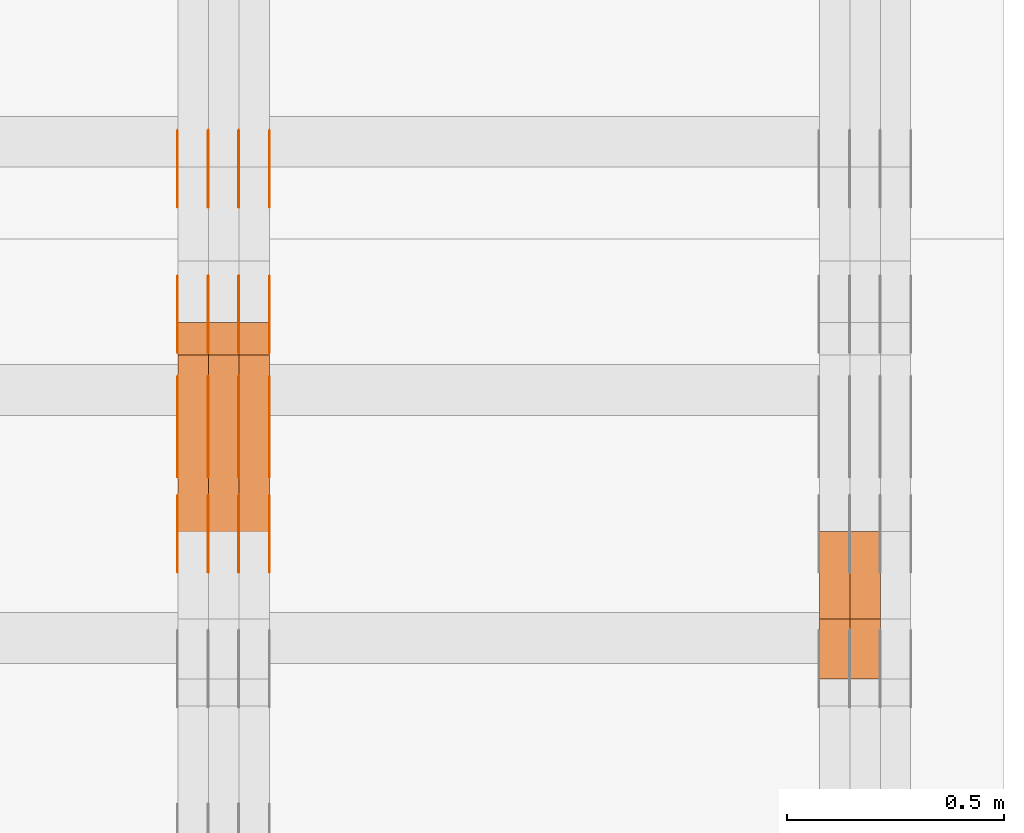
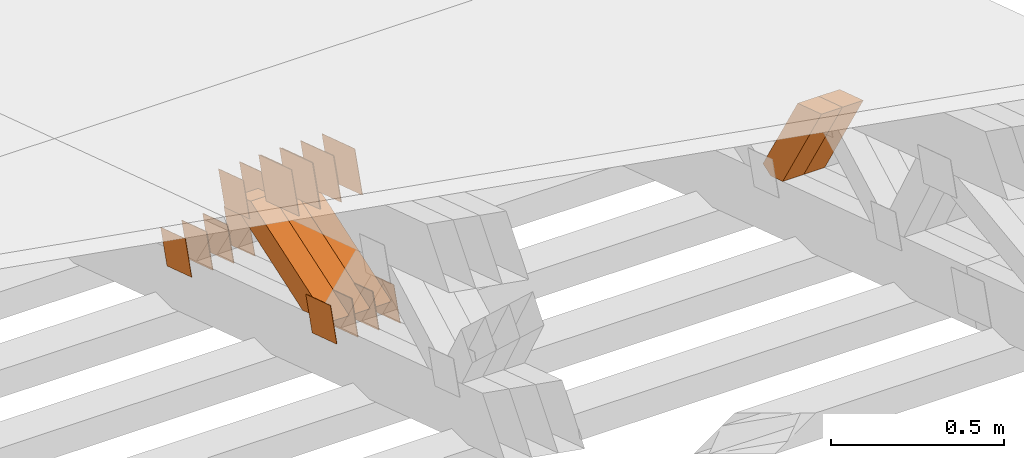
# One storey, part 366 of 385: 29 proxies.
"""IFC2X3 building model written with IfcOpenShell, lengths in millimetres."""

from ifc_helpers import new_model, entity, si_unit, converted_unit, derived_unit, direction, frame, origin, place, context, subcontext, project, spatial, polyline, outline, extrude, source, transform, mapped, material, type_object, type_shapes, element, save


model = new_model("IFC2X3")

# Units and contexts
model_context = context("Model", 3, precision=0.01, world=origin(), true_north=direction((6.12303176911189e-17, 1.0)))
body_context = subcontext(model_context, "Body", "Model", "MODEL_VIEW")
ifc_project = project(units=[si_unit("LENGTHUNIT", "METRE", prefix="MILLI"), si_unit("AREAUNIT", "SQUARE_METRE"), si_unit("VOLUMEUNIT", "CUBIC_METRE"), converted_unit("PLANEANGLEUNIT", "DEGREE", entity("IfcRatioMeasure", 0.0174532925199433), si_unit("PLANEANGLEUNIT", "RADIAN"), dimensions=[0, 0, 0, 0, 0, 0, 0]), si_unit("MASSUNIT", "GRAM", prefix="KILO"), derived_unit("MASSDENSITYUNIT", [(si_unit("MASSUNIT", "GRAM", prefix="KILO"), 1), (si_unit("LENGTHUNIT", "METRE"), -3)]), si_unit("TIMEUNIT", "SECOND"), si_unit("FREQUENCYUNIT", "HERTZ"), si_unit("THERMODYNAMICTEMPERATUREUNIT", "DEGREE_CELSIUS"), derived_unit("THERMALTRANSMITTANCEUNIT", [(si_unit("MASSUNIT", "GRAM", prefix="KILO"), 1), (si_unit("THERMODYNAMICTEMPERATUREUNIT", "KELVIN"), -1), (si_unit("TIMEUNIT", "SECOND"), -3)]), derived_unit("VOLUMETRICFLOWRATEUNIT", [(si_unit("LENGTHUNIT", "METRE"), 3), (si_unit("TIMEUNIT", "SECOND"), -1)]), si_unit("ELECTRICCURRENTUNIT", "AMPERE"), si_unit("ELECTRICVOLTAGEUNIT", "VOLT"), si_unit("POWERUNIT", "WATT"), si_unit("FORCEUNIT", "NEWTON", prefix="KILO"), si_unit("ILLUMINANCEUNIT", "LUX"), si_unit("LUMINOUSFLUXUNIT", "LUMEN"), si_unit("LUMINOUSINTENSITYUNIT", "CANDELA"), derived_unit("USERDEFINED", [(si_unit("MASSUNIT", "GRAM", prefix="KILO"), -1), (si_unit("LENGTHUNIT", "METRE"), -2), (si_unit("TIMEUNIT", "SECOND"), 3), (si_unit("LUMINOUSFLUXUNIT", "LUMEN"), 1)]), derived_unit("LINEARVELOCITYUNIT", [(si_unit("LENGTHUNIT", "METRE"), 1), (si_unit("TIMEUNIT", "SECOND"), -1)]), si_unit("PRESSUREUNIT", "PASCAL"), derived_unit("USERDEFINED", [(si_unit("LENGTHUNIT", "METRE"), -2), (si_unit("MASSUNIT", "GRAM", prefix="KILO"), 1), (si_unit("TIMEUNIT", "SECOND"), -2)])], contexts=[model_context])

# Site, building, storey
site_placement = place(None, origin())
site = spatial("IfcSite", under=ifc_project, at=site_placement, CompositionType="ELEMENT")
building_placement = place(site_placement, origin())
building = spatial("IfcBuilding", under=site, at=building_placement, CompositionType="ELEMENT")
storey_placement = place(building_placement, origin())
storey = spatial("IfcBuildingStorey", under=building, at=storey_placement, Name="Default", CompositionType="ELEMENT", Elevation=0.0)

# Proxies
ifc_material_1 = material(Name="IfcSurfaceStyle #599920")
building_element_proxy_type_1 = type_object("IfcBuildingElementProxyType", Name="T2-W34 599918", PredefinedType="NOTDEFINED", material=ifc_material_1)
shared_shape_1 = source(origin(), body_context, "Body", "SweptSolid", [
    extrude(outline(polyline([(-197.657161937088, -47.499796538607), (193.17680883218, -47.499796538607), (182.92464491562, -1.98968224184526e-05), (128.354123102956, 47.4998064870182), (-306.798414913668, 47.4998064870182), (-197.657161937088, -47.499796538607)])), frame((193.176852028916, 47.4998566383869, 0.0), z_axis=(0.0, 0.0, 1.0), x_axis=(-1.0, 0.0, 0.0)), (0.0, 0.0, 1.0), 70.0),
])
type_shapes(building_element_proxy_type_1, [shared_shape_1])
proxy_1_placement = place(building_placement, frame((49790.0, 19987.8030409043, 2165.75390635484), z_axis=(-1.0, 0.0, 0.0), x_axis=(0.0, -0.514479403471631, 0.857502736674044)))
element("IfcBuildingElementProxy", 1, at=proxy_1_placement, inside=storey, type_object=building_element_proxy_type_1, material=ifc_material_1, Name="T2-W34", context=body_context, shape_type="MappedRepresentation", body=[
    mapped(shared_shape_1, transform((0.0, 0.0, 0.0), scale=1.0)),
])
ifc_material_2 = material(Name="IfcSurfaceStyle #599854")
building_element_proxy_type_2 = type_object("IfcBuildingElementProxyType", Name="T2-W34 599852", PredefinedType="NOTDEFINED", material=ifc_material_2)
shared_shape_2 = source(origin(), body_context, "Body", "SweptSolid", [
    extrude(outline(polyline([(-197.657161937088, -47.499796538607), (193.17680883218, -47.499796538607), (182.92464491562, -1.98968224184526e-05), (128.354123102956, 47.4998064870182), (-306.798414913668, 47.4998064870182), (-197.657161937088, -47.499796538607)])), frame((193.176852028916, 47.4998566383869, 0.0), z_axis=(0.0, 0.0, 1.0), x_axis=(-1.0, 0.0, 0.0)), (0.0, 0.0, 1.0), 70.0),
])
type_shapes(building_element_proxy_type_2, [shared_shape_2])
proxy_2_placement = place(building_placement, frame((49720.0, 19987.8030409043, 2165.75390635484), z_axis=(-1.0, 0.0, 0.0), x_axis=(0.0, -0.514479403471631, 0.857502736674044)))
element("IfcBuildingElementProxy", 2, at=proxy_2_placement, inside=storey, type_object=building_element_proxy_type_2, material=ifc_material_2, Name="T2-W34", context=body_context, shape_type="MappedRepresentation", body=[
    mapped(shared_shape_2, transform((0.0, 0.0, 0.0), scale=1.0)),
])
ifc_material_3 = material(Name="IfcSurfaceStyle #590970")
building_element_proxy_type_3 = type_object("IfcBuildingElementProxyType", PredefinedType="NOTDEFINED", material=ifc_material_3)
shared_shape_3 = source(origin(), body_context, "Body", "SweptSolid", [
    extrude(outline(polyline([(-74.9998605591059, -59.9999264677526), (74.999875428623, -59.9999264677526), (74.9998605591068, 59.9999264677526), (-74.9998754286239, 59.9999264677526), (-74.9998605591059, -59.9999264677526)])), frame((75.0000889884782, 60.0000460315623, 0.0), z_axis=(0.0, 0.0, 1.0), x_axis=(-1.0, 0.0, 0.0)), (0.0, 0.0, 1.0), 1.3),
])
type_shapes(building_element_proxy_type_3, [shared_shape_3])
proxy_3_placement = place(building_placement, frame((48386.3, 20621.9679769682, 2241.76551219004), z_axis=(-1.0, 0.0, 0.0), x_axis=(0.0, -0.951056516295154, 0.309016994374948)))
element("IfcBuildingElementProxy", 3, at=proxy_3_placement, inside=storey, type_object=building_element_proxy_type_3, material=ifc_material_3, context=body_context, shape_type="MappedRepresentation", body=[
    mapped(shared_shape_3, transform((0.0, 0.0, 0.0), scale=1.0)),
])
ifc_material_4 = material(Name="IfcSurfaceStyle #590913")
building_element_proxy_type_4 = type_object("IfcBuildingElementProxyType", PredefinedType="NOTDEFINED", material=ifc_material_4)
shared_shape_4 = source(origin(), body_context, "Body", "SweptSolid", [
    extrude(outline(polyline([(-74.9998605591059, -59.9999264677526), (74.999875428623, -59.9999264677526), (74.9998605591068, 59.9999264677526), (-74.9998754286239, 59.9999264677526), (-74.9998605591059, -59.9999264677526)])), frame((75.0000889884782, 60.0000460315623, 0.0), z_axis=(0.0, 0.0, 1.0), x_axis=(-1.0, 0.0, 0.0)), (0.0, 0.0, 1.0), 1.3),
])
type_shapes(building_element_proxy_type_4, [shared_shape_4])
proxy_4_placement = place(building_placement, frame((48315.0, 20621.9679769682, 2241.76551219004), z_axis=(-1.0, 0.0, 0.0), x_axis=(0.0, -0.951056516295154, 0.309016994374948)))
element("IfcBuildingElementProxy", 4, at=proxy_4_placement, inside=storey, type_object=building_element_proxy_type_4, material=ifc_material_4, context=body_context, shape_type="MappedRepresentation", body=[
    mapped(shared_shape_4, transform((0.0, 0.0, 0.0), scale=1.0)),
])
ifc_material_5 = material(Name="IfcSurfaceStyle #590856")
building_element_proxy_type_5 = type_object("IfcBuildingElementProxyType", PredefinedType="NOTDEFINED", material=ifc_material_5)
shared_shape_5 = source(origin(), body_context, "Body", "SweptSolid", [
    extrude(outline(polyline([(-74.9998605591059, -59.9999264677526), (74.999875428623, -59.9999264677526), (74.9998605591068, 59.9999264677526), (-74.9998754286239, 59.9999264677526), (-74.9998605591059, -59.9999264677526)])), frame((75.0000889884782, 60.0000460315623, 0.0), z_axis=(0.0, 0.0, 1.0), x_axis=(-1.0, 0.0, 0.0)), (0.0, 0.0, 1.0), 1.3),
])
type_shapes(building_element_proxy_type_5, [shared_shape_5])
proxy_5_placement = place(building_placement, frame((48316.3, 20621.9679769682, 2241.76551219004), z_axis=(-1.0, 0.0, 0.0), x_axis=(0.0, -0.951056516295154, 0.309016994374948)))
element("IfcBuildingElementProxy", 5, at=proxy_5_placement, inside=storey, type_object=building_element_proxy_type_5, material=ifc_material_5, context=body_context, shape_type="MappedRepresentation", body=[
    mapped(shared_shape_5, transform((0.0, 0.0, 0.0), scale=1.0)),
])
ifc_material_6 = material(Name="IfcSurfaceStyle #590799")
building_element_proxy_type_6 = type_object("IfcBuildingElementProxyType", PredefinedType="NOTDEFINED", material=ifc_material_6)
shared_shape_6 = source(origin(), body_context, "Body", "SweptSolid", [
    extrude(outline(polyline([(-74.9998605591059, -59.9999264677526), (74.999875428623, -59.9999264677526), (74.9998605591068, 59.9999264677526), (-74.9998754286239, 59.9999264677526), (-74.9998605591059, -59.9999264677526)])), frame((75.0000889884782, 60.0000460315623, 0.0), z_axis=(0.0, 0.0, 1.0), x_axis=(-1.0, 0.0, 0.0)), (0.0, 0.0, 1.0), 1.29999999999999),
])
type_shapes(building_element_proxy_type_6, [shared_shape_6])
proxy_6_placement = place(building_placement, frame((48245.0, 20621.9679769682, 2241.76551219004), z_axis=(-1.0, 0.0, 0.0), x_axis=(0.0, -0.951056516295154, 0.309016994374948)))
element("IfcBuildingElementProxy", 6, at=proxy_6_placement, inside=storey, type_object=building_element_proxy_type_6, material=ifc_material_6, context=body_context, shape_type="MappedRepresentation", body=[
    mapped(shared_shape_6, transform((0.0, 0.0, 0.0), scale=1.0)),
])
ifc_material_7 = material(Name="IfcSurfaceStyle #590742")
building_element_proxy_type_7 = type_object("IfcBuildingElementProxyType", PredefinedType="NOTDEFINED", material=ifc_material_7)
shared_shape_7 = source(origin(), body_context, "Body", "SweptSolid", [
    extrude(outline(polyline([(-74.9998605591059, -59.9999264677526), (74.999875428623, -59.9999264677526), (74.9998605591068, 59.9999264677526), (-74.9998754286239, 59.9999264677526), (-74.9998605591059, -59.9999264677526)])), frame((75.0000889884782, 60.0000460315623, 0.0), z_axis=(0.0, 0.0, 1.0), x_axis=(-1.0, 0.0, 0.0)), (0.0, 0.0, 1.0), 1.29999999999999),
])
type_shapes(building_element_proxy_type_7, [shared_shape_7])
proxy_7_placement = place(building_placement, frame((48246.3, 20621.9679769682, 2241.76551219004), z_axis=(-1.0, 0.0, 0.0), x_axis=(0.0, -0.951056516295154, 0.309016994374948)))
element("IfcBuildingElementProxy", 7, at=proxy_7_placement, inside=storey, type_object=building_element_proxy_type_7, material=ifc_material_7, context=body_context, shape_type="MappedRepresentation", body=[
    mapped(shared_shape_7, transform((0.0, 0.0, 0.0), scale=1.0)),
])
ifc_material_8 = material(Name="IfcSurfaceStyle #590685")
building_element_proxy_type_8 = type_object("IfcBuildingElementProxyType", PredefinedType="NOTDEFINED", material=ifc_material_8)
shared_shape_8 = source(origin(), body_context, "Body", "SweptSolid", [
    extrude(outline(polyline([(-74.9998605591059, -59.9999264677526), (74.999875428623, -59.9999264677526), (74.9998605591068, 59.9999264677526), (-74.9998754286239, 59.9999264677526), (-74.9998605591059, -59.9999264677526)])), frame((75.0000889884782, 60.0000460315623, 0.0), z_axis=(0.0, 0.0, 1.0), x_axis=(-1.0, 0.0, 0.0)), (0.0, 0.0, 1.0), 1.29999999999999),
])
type_shapes(building_element_proxy_type_8, [shared_shape_8])
proxy_8_placement = place(building_placement, frame((48175.0, 20621.9679769682, 2241.76551219004), z_axis=(-1.0, 0.0, 0.0), x_axis=(0.0, -0.951056516295154, 0.309016994374948)))
element("IfcBuildingElementProxy", 8, at=proxy_8_placement, inside=storey, type_object=building_element_proxy_type_8, material=ifc_material_8, context=body_context, shape_type="MappedRepresentation", body=[
    mapped(shared_shape_8, transform((0.0, 0.0, 0.0), scale=1.0)),
])
ifc_material_9 = material(Name="IfcSurfaceStyle #589260")
building_element_proxy_type_9 = type_object("IfcBuildingElementProxyType", PredefinedType="NOTDEFINED", material=ifc_material_9)
shared_shape_9 = source(origin(), body_context, "Body", "SweptSolid", [
    extrude(outline(polyline([(-100.000260677523, -72.0000050220369), (100.000341220114, -72.0000050220369), (99.9997962944585, 72.0000050220369), (-99.9998768370492, 72.0000050220369), (-100.000260677523, -72.0000050220369)])), frame((100.000341220114, 72.0001826453454, 0.0), z_axis=(0.0, 0.0, 1.0), x_axis=(-1.0, 0.0, 0.0)), (0.0, 0.0, 1.0), 1.3),
])
type_shapes(building_element_proxy_type_9, [shared_shape_9])
proxy_9_placement = place(building_placement, frame((48386.3, 20382.8706354426, 2409.35285895246), z_axis=(-1.0, 0.0, 0.0), x_axis=(0.0, -0.951056516295154, 0.309016994374948)))
element("IfcBuildingElementProxy", 9, at=proxy_9_placement, inside=storey, type_object=building_element_proxy_type_9, material=ifc_material_9, context=body_context, shape_type="MappedRepresentation", body=[
    mapped(shared_shape_9, transform((0.0, 0.0, 0.0), scale=1.0)),
])
ifc_material_10 = material(Name="IfcSurfaceStyle #589203")
building_element_proxy_type_10 = type_object("IfcBuildingElementProxyType", PredefinedType="NOTDEFINED", material=ifc_material_10)
shared_shape_10 = source(origin(), body_context, "Body", "SweptSolid", [
    extrude(outline(polyline([(-100.000260677523, -72.0000050220369), (100.000341220114, -72.0000050220369), (99.9997962944585, 72.0000050220369), (-99.9998768370492, 72.0000050220369), (-100.000260677523, -72.0000050220369)])), frame((100.000341220114, 72.0001826453454, 0.0), z_axis=(0.0, 0.0, 1.0), x_axis=(-1.0, 0.0, 0.0)), (0.0, 0.0, 1.0), 1.3),
])
type_shapes(building_element_proxy_type_10, [shared_shape_10])
proxy_10_placement = place(building_placement, frame((48315.0, 20382.8706354426, 2409.35285895246), z_axis=(-1.0, 0.0, 0.0), x_axis=(0.0, -0.951056516295154, 0.309016994374948)))
element("IfcBuildingElementProxy", 10, at=proxy_10_placement, inside=storey, type_object=building_element_proxy_type_10, material=ifc_material_10, context=body_context, shape_type="MappedRepresentation", body=[
    mapped(shared_shape_10, transform((0.0, 0.0, 0.0), scale=1.0)),
])
ifc_material_11 = material(Name="IfcSurfaceStyle #589146")
building_element_proxy_type_11 = type_object("IfcBuildingElementProxyType", PredefinedType="NOTDEFINED", material=ifc_material_11)
shared_shape_11 = source(origin(), body_context, "Body", "SweptSolid", [
    extrude(outline(polyline([(-100.000260677523, -72.0000050220369), (100.000341220114, -72.0000050220369), (99.9997962944585, 72.0000050220369), (-99.9998768370492, 72.0000050220369), (-100.000260677523, -72.0000050220369)])), frame((100.000341220114, 72.0001826453454, 0.0), z_axis=(0.0, 0.0, 1.0), x_axis=(-1.0, 0.0, 0.0)), (0.0, 0.0, 1.0), 1.3),
])
type_shapes(building_element_proxy_type_11, [shared_shape_11])
proxy_11_placement = place(building_placement, frame((48316.3, 20382.8706354426, 2409.35285895246), z_axis=(-1.0, 0.0, 0.0), x_axis=(0.0, -0.951056516295154, 0.309016994374948)))
element("IfcBuildingElementProxy", 11, at=proxy_11_placement, inside=storey, type_object=building_element_proxy_type_11, material=ifc_material_11, context=body_context, shape_type="MappedRepresentation", body=[
    mapped(shared_shape_11, transform((0.0, 0.0, 0.0), scale=1.0)),
])
ifc_material_12 = material(Name="IfcSurfaceStyle #589089")
building_element_proxy_type_12 = type_object("IfcBuildingElementProxyType", PredefinedType="NOTDEFINED", material=ifc_material_12)
shared_shape_12 = source(origin(), body_context, "Body", "SweptSolid", [
    extrude(outline(polyline([(-100.000260677523, -72.0000050220369), (100.000341220114, -72.0000050220369), (99.9997962944585, 72.0000050220369), (-99.9998768370492, 72.0000050220369), (-100.000260677523, -72.0000050220369)])), frame((100.000341220114, 72.0001826453454, 0.0), z_axis=(0.0, 0.0, 1.0), x_axis=(-1.0, 0.0, 0.0)), (0.0, 0.0, 1.0), 1.29999999999998),
])
type_shapes(building_element_proxy_type_12, [shared_shape_12])
proxy_12_placement = place(building_placement, frame((48245.0, 20382.8706354426, 2409.35285895246), z_axis=(-1.0, 0.0, 0.0), x_axis=(0.0, -0.951056516295154, 0.309016994374948)))
element("IfcBuildingElementProxy", 12, at=proxy_12_placement, inside=storey, type_object=building_element_proxy_type_12, material=ifc_material_12, context=body_context, shape_type="MappedRepresentation", body=[
    mapped(shared_shape_12, transform((0.0, 0.0, 0.0), scale=1.0)),
])
ifc_material_13 = material(Name="IfcSurfaceStyle #589032")
building_element_proxy_type_13 = type_object("IfcBuildingElementProxyType", PredefinedType="NOTDEFINED", material=ifc_material_13)
shared_shape_13 = source(origin(), body_context, "Body", "SweptSolid", [
    extrude(outline(polyline([(-100.000260677523, -72.0000050220369), (100.000341220114, -72.0000050220369), (99.9997962944585, 72.0000050220369), (-99.9998768370492, 72.0000050220369), (-100.000260677523, -72.0000050220369)])), frame((100.000341220114, 72.0001826453454, 0.0), z_axis=(0.0, 0.0, 1.0), x_axis=(-1.0, 0.0, 0.0)), (0.0, 0.0, 1.0), 1.29999999999998),
])
type_shapes(building_element_proxy_type_13, [shared_shape_13])
proxy_13_placement = place(building_placement, frame((48246.3, 20382.8706354426, 2409.35285895246), z_axis=(-1.0, 0.0, 0.0), x_axis=(0.0, -0.951056516295154, 0.309016994374948)))
element("IfcBuildingElementProxy", 13, at=proxy_13_placement, inside=storey, type_object=building_element_proxy_type_13, material=ifc_material_13, context=body_context, shape_type="MappedRepresentation", body=[
    mapped(shared_shape_13, transform((0.0, 0.0, 0.0), scale=1.0)),
])
ifc_material_14 = material(Name="IfcSurfaceStyle #588975")
building_element_proxy_type_14 = type_object("IfcBuildingElementProxyType", PredefinedType="NOTDEFINED", material=ifc_material_14)
shared_shape_14 = source(origin(), body_context, "Body", "SweptSolid", [
    extrude(outline(polyline([(-100.000260677523, -72.0000050220369), (100.000341220114, -72.0000050220369), (99.9997962944585, 72.0000050220369), (-99.9998768370492, 72.0000050220369), (-100.000260677523, -72.0000050220369)])), frame((100.000341220114, 72.0001826453454, 0.0), z_axis=(0.0, 0.0, 1.0), x_axis=(-1.0, 0.0, 0.0)), (0.0, 0.0, 1.0), 1.29999999999999),
])
type_shapes(building_element_proxy_type_14, [shared_shape_14])
proxy_14_placement = place(building_placement, frame((48175.0, 20382.8706354426, 2409.35285895246), z_axis=(-1.0, 0.0, 0.0), x_axis=(0.0, -0.951056516295154, 0.309016994374948)))
element("IfcBuildingElementProxy", 14, at=proxy_14_placement, inside=storey, type_object=building_element_proxy_type_14, material=ifc_material_14, context=body_context, shape_type="MappedRepresentation", body=[
    mapped(shared_shape_14, transform((0.0, 0.0, 0.0), scale=1.0)),
])
ifc_material_15 = material(Name="IfcSurfaceStyle #582762")
building_element_proxy_type_15 = type_object("IfcBuildingElementProxyType", PredefinedType="NOTDEFINED", material=ifc_material_15)
shared_shape_15 = source(origin(), body_context, "Body", "SweptSolid", [
    extrude(outline(polyline([(-74.9998605591118, -59.9999264677598), (74.9998754286171, -59.9999264677598), (74.9998605591136, 59.9999264677598), (-74.9998754286189, 59.9999264677598), (-74.9998605591118, -59.9999264677598)])), frame((75.0000347664736, 60.0000016373434, 0.0), z_axis=(0.0, 0.0, 1.0), x_axis=(-1.0, 0.0, 0.0)), (0.0, 0.0, 1.0), 1.3),
])
type_shapes(building_element_proxy_type_15, [shared_shape_15])
proxy_15_placement = place(building_placement, frame((48386.3, 20117.0890328686, 2105.40814929196), z_axis=(-1.0, 0.0, 0.0), x_axis=(0.0, -0.951056516295124, 0.309016994375039)))
element("IfcBuildingElementProxy", 15, at=proxy_15_placement, inside=storey, type_object=building_element_proxy_type_15, material=ifc_material_15, context=body_context, shape_type="MappedRepresentation", body=[
    mapped(shared_shape_15, transform((0.0, 0.0, 0.0), scale=1.0)),
])
ifc_material_16 = material(Name="IfcSurfaceStyle #582705")
building_element_proxy_type_16 = type_object("IfcBuildingElementProxyType", PredefinedType="NOTDEFINED", material=ifc_material_16)
shared_shape_16 = source(origin(), body_context, "Body", "SweptSolid", [
    extrude(outline(polyline([(-74.9998605591118, -59.9999264677598), (74.9998754286171, -59.9999264677598), (74.9998605591136, 59.9999264677598), (-74.9998754286189, 59.9999264677598), (-74.9998605591118, -59.9999264677598)])), frame((75.0000347664736, 60.0000016373434, 0.0), z_axis=(0.0, 0.0, 1.0), x_axis=(-1.0, 0.0, 0.0)), (0.0, 0.0, 1.0), 1.3),
])
type_shapes(building_element_proxy_type_16, [shared_shape_16])
proxy_16_placement = place(building_placement, frame((48315.0, 20117.0890328686, 2105.40814929196), z_axis=(-1.0, 0.0, 0.0), x_axis=(0.0, -0.951056516295124, 0.309016994375039)))
element("IfcBuildingElementProxy", 16, at=proxy_16_placement, inside=storey, type_object=building_element_proxy_type_16, material=ifc_material_16, context=body_context, shape_type="MappedRepresentation", body=[
    mapped(shared_shape_16, transform((0.0, 0.0, 0.0), scale=1.0)),
])
ifc_material_17 = material(Name="IfcSurfaceStyle #582648")
building_element_proxy_type_17 = type_object("IfcBuildingElementProxyType", PredefinedType="NOTDEFINED", material=ifc_material_17)
shared_shape_17 = source(origin(), body_context, "Body", "SweptSolid", [
    extrude(outline(polyline([(-74.9998605591118, -59.9999264677598), (74.9998754286171, -59.9999264677598), (74.9998605591136, 59.9999264677598), (-74.9998754286189, 59.9999264677598), (-74.9998605591118, -59.9999264677598)])), frame((75.0000347664736, 60.0000016373434, 0.0), z_axis=(0.0, 0.0, 1.0), x_axis=(-1.0, 0.0, 0.0)), (0.0, 0.0, 1.0), 1.3),
])
type_shapes(building_element_proxy_type_17, [shared_shape_17])
proxy_17_placement = place(building_placement, frame((48316.3, 20117.0890328686, 2105.40814929196), z_axis=(-1.0, 0.0, 0.0), x_axis=(0.0, -0.951056516295124, 0.309016994375039)))
element("IfcBuildingElementProxy", 17, at=proxy_17_placement, inside=storey, type_object=building_element_proxy_type_17, material=ifc_material_17, context=body_context, shape_type="MappedRepresentation", body=[
    mapped(shared_shape_17, transform((0.0, 0.0, 0.0), scale=1.0)),
])
ifc_material_18 = material(Name="IfcSurfaceStyle #582591")
building_element_proxy_type_18 = type_object("IfcBuildingElementProxyType", PredefinedType="NOTDEFINED", material=ifc_material_18)
shared_shape_18 = source(origin(), body_context, "Body", "SweptSolid", [
    extrude(outline(polyline([(-74.9998605591118, -59.9999264677598), (74.9998754286171, -59.9999264677598), (74.9998605591136, 59.9999264677598), (-74.9998754286189, 59.9999264677598), (-74.9998605591118, -59.9999264677598)])), frame((75.0000347664736, 60.0000016373434, 0.0), z_axis=(0.0, 0.0, 1.0), x_axis=(-1.0, 0.0, 0.0)), (0.0, 0.0, 1.0), 1.29999999999999),
])
type_shapes(building_element_proxy_type_18, [shared_shape_18])
proxy_18_placement = place(building_placement, frame((48245.0, 20117.0890328686, 2105.40814929196), z_axis=(-1.0, 0.0, 0.0), x_axis=(0.0, -0.951056516295124, 0.309016994375039)))
element("IfcBuildingElementProxy", 18, at=proxy_18_placement, inside=storey, type_object=building_element_proxy_type_18, material=ifc_material_18, context=body_context, shape_type="MappedRepresentation", body=[
    mapped(shared_shape_18, transform((0.0, 0.0, 0.0), scale=1.0)),
])
ifc_material_19 = material(Name="IfcSurfaceStyle #582534")
building_element_proxy_type_19 = type_object("IfcBuildingElementProxyType", PredefinedType="NOTDEFINED", material=ifc_material_19)
shared_shape_19 = source(origin(), body_context, "Body", "SweptSolid", [
    extrude(outline(polyline([(-74.9998605591118, -59.9999264677598), (74.9998754286171, -59.9999264677598), (74.9998605591136, 59.9999264677598), (-74.9998754286189, 59.9999264677598), (-74.9998605591118, -59.9999264677598)])), frame((75.0000347664736, 60.0000016373434, 0.0), z_axis=(0.0, 0.0, 1.0), x_axis=(-1.0, 0.0, 0.0)), (0.0, 0.0, 1.0), 1.29999999999999),
])
type_shapes(building_element_proxy_type_19, [shared_shape_19])
proxy_19_placement = place(building_placement, frame((48246.3, 20117.0890328686, 2105.40814929196), z_axis=(-1.0, 0.0, 0.0), x_axis=(0.0, -0.951056516295124, 0.309016994375039)))
element("IfcBuildingElementProxy", 19, at=proxy_19_placement, inside=storey, type_object=building_element_proxy_type_19, material=ifc_material_19, context=body_context, shape_type="MappedRepresentation", body=[
    mapped(shared_shape_19, transform((0.0, 0.0, 0.0), scale=1.0)),
])
ifc_material_20 = material(Name="IfcSurfaceStyle #582477")
building_element_proxy_type_20 = type_object("IfcBuildingElementProxyType", PredefinedType="NOTDEFINED", material=ifc_material_20)
shared_shape_20 = source(origin(), body_context, "Body", "SweptSolid", [
    extrude(outline(polyline([(-74.9998605591118, -59.9999264677598), (74.9998754286171, -59.9999264677598), (74.9998605591136, 59.9999264677598), (-74.9998754286189, 59.9999264677598), (-74.9998605591118, -59.9999264677598)])), frame((75.0000347664736, 60.0000016373434, 0.0), z_axis=(0.0, 0.0, 1.0), x_axis=(-1.0, 0.0, 0.0)), (0.0, 0.0, 1.0), 1.29999999999999),
])
type_shapes(building_element_proxy_type_20, [shared_shape_20])
proxy_20_placement = place(building_placement, frame((48175.0, 20117.0890328686, 2105.40814929196), z_axis=(-1.0, 0.0, 0.0), x_axis=(0.0, -0.951056516295124, 0.309016994375039)))
element("IfcBuildingElementProxy", 20, at=proxy_20_placement, inside=storey, type_object=building_element_proxy_type_20, material=ifc_material_20, context=body_context, shape_type="MappedRepresentation", body=[
    mapped(shared_shape_20, transform((0.0, 0.0, 0.0), scale=1.0)),
])
ifc_material_21 = material(Name="IfcSurfaceStyle #582420")
building_element_proxy_type_21 = type_object("IfcBuildingElementProxyType", PredefinedType="NOTDEFINED", material=ifc_material_21)
shared_shape_21 = source(origin(), body_context, "Body", "SweptSolid", [
    extrude(outline(polyline([(-74.9998794200132, -59.999984515643), (74.9998565677174, -59.999984515643), (74.9998794200123, 59.999984515643), (-74.9998565677165, 59.999984515643), (-74.9998794200132, -59.999984515643)])), frame((75.0002235343086, 60.0000596852268, 0.0), z_axis=(0.0, 0.0, 1.0), x_axis=(-1.0, 0.0, 0.0)), (0.0, 0.0, 1.0), 1.3),
])
type_shapes(building_element_proxy_type_21, [shared_shape_21])
proxy_21_placement = place(building_placement, frame((48386.3, 20956.2317725847, 1832.75404405346), z_axis=(-1.0, 0.0, 0.0), x_axis=(0.0, -0.951056516295124, 0.309016994375039)))
element("IfcBuildingElementProxy", 21, at=proxy_21_placement, inside=storey, type_object=building_element_proxy_type_21, material=ifc_material_21, context=body_context, shape_type="MappedRepresentation", body=[
    mapped(shared_shape_21, transform((0.0, 0.0, 0.0), scale=1.0)),
])
ifc_material_22 = material(Name="IfcSurfaceStyle #582363")
building_element_proxy_type_22 = type_object("IfcBuildingElementProxyType", PredefinedType="NOTDEFINED", material=ifc_material_22)
shared_shape_22 = source(origin(), body_context, "Body", "SweptSolid", [
    extrude(outline(polyline([(-74.9998794200132, -59.999984515643), (74.9998565677174, -59.999984515643), (74.9998794200123, 59.999984515643), (-74.9998565677165, 59.999984515643), (-74.9998794200132, -59.999984515643)])), frame((75.0002235343086, 60.0000596852268, 0.0), z_axis=(0.0, 0.0, 1.0), x_axis=(-1.0, 0.0, 0.0)), (0.0, 0.0, 1.0), 1.3),
])
type_shapes(building_element_proxy_type_22, [shared_shape_22])
proxy_22_placement = place(building_placement, frame((48315.0, 20956.2317725847, 1832.75404405346), z_axis=(-1.0, 0.0, 0.0), x_axis=(0.0, -0.951056516295124, 0.309016994375039)))
element("IfcBuildingElementProxy", 22, at=proxy_22_placement, inside=storey, type_object=building_element_proxy_type_22, material=ifc_material_22, context=body_context, shape_type="MappedRepresentation", body=[
    mapped(shared_shape_22, transform((0.0, 0.0, 0.0), scale=1.0)),
])
ifc_material_23 = material(Name="IfcSurfaceStyle #582306")
building_element_proxy_type_23 = type_object("IfcBuildingElementProxyType", PredefinedType="NOTDEFINED", material=ifc_material_23)
shared_shape_23 = source(origin(), body_context, "Body", "SweptSolid", [
    extrude(outline(polyline([(-74.9998794200132, -59.999984515643), (74.9998565677174, -59.999984515643), (74.9998794200123, 59.999984515643), (-74.9998565677165, 59.999984515643), (-74.9998794200132, -59.999984515643)])), frame((75.0002235343086, 60.0000596852268, 0.0), z_axis=(0.0, 0.0, 1.0), x_axis=(-1.0, 0.0, 0.0)), (0.0, 0.0, 1.0), 1.3),
])
type_shapes(building_element_proxy_type_23, [shared_shape_23])
proxy_23_placement = place(building_placement, frame((48316.3, 20956.2317725847, 1832.75404405346), z_axis=(-1.0, 0.0, 0.0), x_axis=(0.0, -0.951056516295124, 0.309016994375039)))
element("IfcBuildingElementProxy", 23, at=proxy_23_placement, inside=storey, type_object=building_element_proxy_type_23, material=ifc_material_23, context=body_context, shape_type="MappedRepresentation", body=[
    mapped(shared_shape_23, transform((0.0, 0.0, 0.0), scale=1.0)),
])
ifc_material_24 = material(Name="IfcSurfaceStyle #582249")
building_element_proxy_type_24 = type_object("IfcBuildingElementProxyType", PredefinedType="NOTDEFINED", material=ifc_material_24)
shared_shape_24 = source(origin(), body_context, "Body", "SweptSolid", [
    extrude(outline(polyline([(-74.9998794200132, -59.999984515643), (74.9998565677174, -59.999984515643), (74.9998794200123, 59.999984515643), (-74.9998565677165, 59.999984515643), (-74.9998794200132, -59.999984515643)])), frame((75.0002235343086, 60.0000596852268, 0.0), z_axis=(0.0, 0.0, 1.0), x_axis=(-1.0, 0.0, 0.0)), (0.0, 0.0, 1.0), 1.29999999999999),
])
type_shapes(building_element_proxy_type_24, [shared_shape_24])
proxy_24_placement = place(building_placement, frame((48245.0, 20956.2317725847, 1832.75404405346), z_axis=(-1.0, 0.0, 0.0), x_axis=(0.0, -0.951056516295124, 0.309016994375039)))
element("IfcBuildingElementProxy", 24, at=proxy_24_placement, inside=storey, type_object=building_element_proxy_type_24, material=ifc_material_24, context=body_context, shape_type="MappedRepresentation", body=[
    mapped(shared_shape_24, transform((0.0, 0.0, 0.0), scale=1.0)),
])
ifc_material_25 = material(Name="IfcSurfaceStyle #582192")
building_element_proxy_type_25 = type_object("IfcBuildingElementProxyType", PredefinedType="NOTDEFINED", material=ifc_material_25)
shared_shape_25 = source(origin(), body_context, "Body", "SweptSolid", [
    extrude(outline(polyline([(-74.9998794200132, -59.999984515643), (74.9998565677174, -59.999984515643), (74.9998794200123, 59.999984515643), (-74.9998565677165, 59.999984515643), (-74.9998794200132, -59.999984515643)])), frame((75.0002235343086, 60.0000596852268, 0.0), z_axis=(0.0, 0.0, 1.0), x_axis=(-1.0, 0.0, 0.0)), (0.0, 0.0, 1.0), 1.29999999999999),
])
type_shapes(building_element_proxy_type_25, [shared_shape_25])
proxy_25_placement = place(building_placement, frame((48246.3, 20956.2317725847, 1832.75404405346), z_axis=(-1.0, 0.0, 0.0), x_axis=(0.0, -0.951056516295124, 0.309016994375039)))
element("IfcBuildingElementProxy", 25, at=proxy_25_placement, inside=storey, type_object=building_element_proxy_type_25, material=ifc_material_25, context=body_context, shape_type="MappedRepresentation", body=[
    mapped(shared_shape_25, transform((0.0, 0.0, 0.0), scale=1.0)),
])
ifc_material_26 = material(Name="IfcSurfaceStyle #582135")
building_element_proxy_type_26 = type_object("IfcBuildingElementProxyType", PredefinedType="NOTDEFINED", material=ifc_material_26)
shared_shape_26 = source(origin(), body_context, "Body", "SweptSolid", [
    extrude(outline(polyline([(-74.9998794200132, -59.999984515643), (74.9998565677174, -59.999984515643), (74.9998794200123, 59.999984515643), (-74.9998565677165, 59.999984515643), (-74.9998794200132, -59.999984515643)])), frame((75.0002235343086, 60.0000596852268, 0.0), z_axis=(0.0, 0.0, 1.0), x_axis=(-1.0, 0.0, 0.0)), (0.0, 0.0, 1.0), 1.29999999999999),
])
type_shapes(building_element_proxy_type_26, [shared_shape_26])
proxy_26_placement = place(building_placement, frame((48175.0, 20956.2317725847, 1832.75404405346), z_axis=(-1.0, 0.0, 0.0), x_axis=(0.0, -0.951056516295124, 0.309016994375039)))
element("IfcBuildingElementProxy", 26, at=proxy_26_placement, inside=storey, type_object=building_element_proxy_type_26, material=ifc_material_26, context=body_context, shape_type="MappedRepresentation", body=[
    mapped(shared_shape_26, transform((0.0, 0.0, 0.0), scale=1.0)),
])
ifc_material_27 = material(Name="IfcSurfaceStyle #565158")
building_element_proxy_type_27 = type_object("IfcBuildingElementProxyType", Name="T1-W26 565156", PredefinedType="NOTDEFINED", material=ifc_material_27)
shared_shape_27 = source(origin(), body_context, "Body", "SweptSolid", [
    extrude(outline(polyline([(-339.390941716546, -47.5001331548025), (137.738864791781, -47.5001331548025), (201.272298560955, 6.02772073885038e-05), (212.703852542003, 47.5001030161988), (-212.324074178193, 47.5001030161988), (-339.390941716546, -47.5001331548025)])), frame((212.703852542003, 47.5001030161988, 0.0), z_axis=(0.0, 0.0, 1.0), x_axis=(-1.0, 0.0, 0.0)), (0.0, 0.0, 1.0), 70.0),
])
type_shapes(building_element_proxy_type_27, [shared_shape_27])
proxy_27_placement = place(building_placement, frame((48385.0, 20576.541015625, 2286.80981445313), z_axis=(-1.0, 0.0, 0.0), x_axis=(0.0, -0.946743816465327, -0.321987804093053)))
element("IfcBuildingElementProxy", 27, at=proxy_27_placement, inside=storey, type_object=building_element_proxy_type_27, material=ifc_material_27, Name="T1-W26", context=body_context, shape_type="MappedRepresentation", body=[
    mapped(shared_shape_27, transform((0.0, 0.0, 0.0), scale=1.0)),
])
ifc_material_28 = material(Name="IfcSurfaceStyle #565092")
building_element_proxy_type_28 = type_object("IfcBuildingElementProxyType", Name="T1-W26 565090", PredefinedType="NOTDEFINED", material=ifc_material_28)
shared_shape_28 = source(origin(), body_context, "Body", "SweptSolid", [
    extrude(outline(polyline([(-339.390941716546, -47.5001331548025), (137.738864791781, -47.5001331548025), (201.272298560955, 6.02772073885038e-05), (212.703852542003, 47.5001030161988), (-212.324074178193, 47.5001030161988), (-339.390941716546, -47.5001331548025)])), frame((212.703852542003, 47.5001030161988, 0.0), z_axis=(0.0, 0.0, 1.0), x_axis=(-1.0, 0.0, 0.0)), (0.0, 0.0, 1.0), 70.0),
])
type_shapes(building_element_proxy_type_28, [shared_shape_28])
proxy_28_placement = place(building_placement, frame((48315.0, 20576.541015625, 2286.80981445313), z_axis=(-1.0, 0.0, 0.0), x_axis=(0.0, -0.946743816465327, -0.321987804093053)))
element("IfcBuildingElementProxy", 28, at=proxy_28_placement, inside=storey, type_object=building_element_proxy_type_28, material=ifc_material_28, Name="T1-W26", context=body_context, shape_type="MappedRepresentation", body=[
    mapped(shared_shape_28, transform((0.0, 0.0, 0.0), scale=1.0)),
])
ifc_material_29 = material(Name="IfcSurfaceStyle #565026")
building_element_proxy_type_29 = type_object("IfcBuildingElementProxyType", Name="T1-W26 565024", PredefinedType="NOTDEFINED", material=ifc_material_29)
shared_shape_29 = source(origin(), body_context, "Body", "SweptSolid", [
    extrude(outline(polyline([(-339.390941716546, -47.5001331548025), (137.738864791781, -47.5001331548025), (201.272298560955, 6.02772073885038e-05), (212.703852542003, 47.5001030161988), (-212.324074178193, 47.5001030161988), (-339.390941716546, -47.5001331548025)])), frame((212.703852542003, 47.5001030161988, 0.0), z_axis=(0.0, 0.0, 1.0), x_axis=(-1.0, 0.0, 0.0)), (0.0, 0.0, 1.0), 70.0),
])
type_shapes(building_element_proxy_type_29, [shared_shape_29])
proxy_29_placement = place(building_placement, frame((48245.0, 20576.541015625, 2286.80981445313), z_axis=(-1.0, 0.0, 0.0), x_axis=(0.0, -0.946743816465327, -0.321987804093053)))
element("IfcBuildingElementProxy", 29, at=proxy_29_placement, inside=storey, type_object=building_element_proxy_type_29, material=ifc_material_29, Name="T1-W26", context=body_context, shape_type="MappedRepresentation", body=[
    mapped(shared_shape_29, transform((0.0, 0.0, 0.0), scale=1.0)),
])

save(model, "model.ifc")
